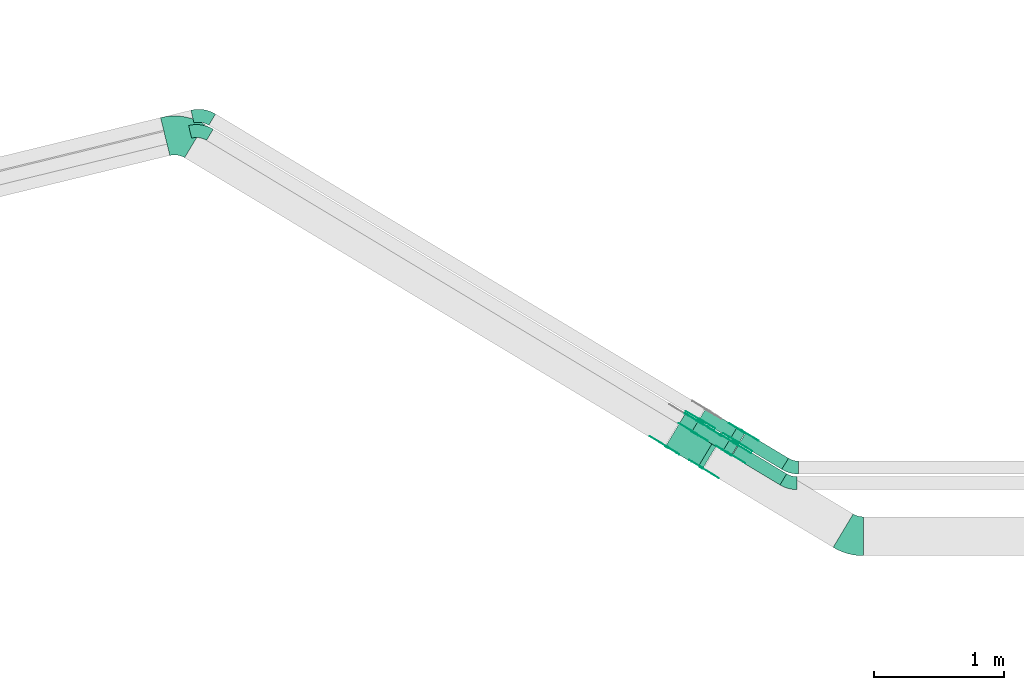
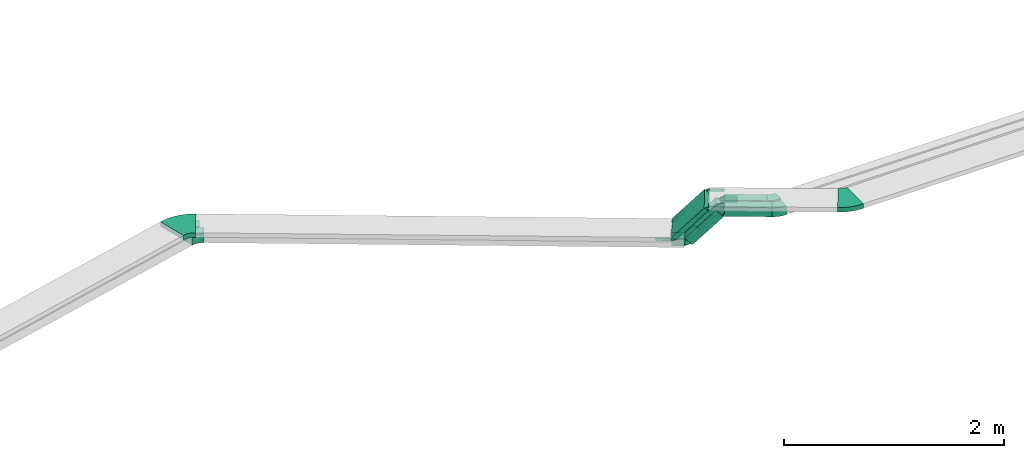
# One storey, part 4 of 28: 27 flow fittings, 5 flow segments.
"""IFC2X3 building model written with IfcOpenShell, lengths in millimetres."""

from ifc_helpers import new_model, entity, si_unit, converted_unit, derived_unit, direction, frame, frame_2d, origin, origin_2d_with_axis, place, context, subcontext, project, spatial, polyline, circle_curve, parameter, trimmed, segment, composite_curve, rectangle, outline, extrude, source, transform, mapped, material, type_object, type_shapes, element, save


model = new_model("IFC2X3")

# Units and contexts
model_context = context("Model", 3, precision=0.01, world=origin(), true_north=direction((6.12303176911189e-17, 1.0)))
body_context = subcontext(model_context, "Body", "Model", "MODEL_VIEW")
ifc_project = project(units=[si_unit("LENGTHUNIT", "METRE", prefix="MILLI"), si_unit("AREAUNIT", "SQUARE_METRE"), si_unit("VOLUMEUNIT", "CUBIC_METRE"), converted_unit("PLANEANGLEUNIT", "DEGREE", entity("IfcRatioMeasure", 0.0174532925199433), si_unit("PLANEANGLEUNIT", "RADIAN"), dimensions=[0, 0, 0, 0, 0, 0, 0]), si_unit("MASSUNIT", "GRAM", prefix="KILO"), derived_unit("MASSDENSITYUNIT", [(si_unit("MASSUNIT", "GRAM", prefix="KILO"), 1), (si_unit("LENGTHUNIT", "METRE"), -3)]), derived_unit("MOMENTOFINERTIAUNIT", [(si_unit("LENGTHUNIT", "METRE"), 4)]), si_unit("TIMEUNIT", "SECOND"), si_unit("FREQUENCYUNIT", "HERTZ"), si_unit("THERMODYNAMICTEMPERATUREUNIT", "DEGREE_CELSIUS"), derived_unit("THERMALTRANSMITTANCEUNIT", [(si_unit("MASSUNIT", "GRAM", prefix="KILO"), 1), (si_unit("THERMODYNAMICTEMPERATUREUNIT", "KELVIN"), -1), (si_unit("TIMEUNIT", "SECOND"), -3)]), derived_unit("VOLUMETRICFLOWRATEUNIT", [(si_unit("LENGTHUNIT", "METRE"), 3), (si_unit("TIMEUNIT", "SECOND"), -1)]), derived_unit("MASSFLOWRATEUNIT", [(si_unit("MASSUNIT", "GRAM", prefix="KILO"), 1), (si_unit("TIMEUNIT", "SECOND"), -1)]), derived_unit("ROTATIONALFREQUENCYUNIT", [(si_unit("TIMEUNIT", "SECOND"), -1)]), si_unit("ELECTRICCURRENTUNIT", "AMPERE"), si_unit("ELECTRICVOLTAGEUNIT", "VOLT"), si_unit("POWERUNIT", "WATT"), si_unit("FORCEUNIT", "NEWTON", prefix="KILO"), si_unit("ILLUMINANCEUNIT", "LUX"), si_unit("LUMINOUSFLUXUNIT", "LUMEN"), si_unit("LUMINOUSINTENSITYUNIT", "CANDELA"), derived_unit("USERDEFINED", [(si_unit("MASSUNIT", "GRAM", prefix="KILO"), -1), (si_unit("LENGTHUNIT", "METRE"), -2), (si_unit("TIMEUNIT", "SECOND"), 3), (si_unit("LUMINOUSFLUXUNIT", "LUMEN"), 1)]), derived_unit("LINEARVELOCITYUNIT", [(si_unit("LENGTHUNIT", "METRE"), 1), (si_unit("TIMEUNIT", "SECOND"), -1)]), si_unit("PRESSUREUNIT", "PASCAL"), derived_unit("USERDEFINED", [(si_unit("LENGTHUNIT", "METRE"), -2), (si_unit("MASSUNIT", "GRAM", prefix="KILO"), 1), (si_unit("TIMEUNIT", "SECOND"), -2)]), derived_unit("LINEARFORCEUNIT", [(si_unit("MASSUNIT", "GRAM", prefix="KILO"), 1), (si_unit("LENGTHUNIT", "METRE"), 1), (si_unit("TIMEUNIT", "SECOND"), -2), (si_unit("LENGTHUNIT", "METRE"), -1)]), derived_unit("PLANARFORCEUNIT", [(si_unit("MASSUNIT", "GRAM", prefix="KILO"), 1), (si_unit("LENGTHUNIT", "METRE"), 1), (si_unit("TIMEUNIT", "SECOND"), -2), (si_unit("LENGTHUNIT", "METRE"), -2)])], contexts=[model_context])

# Site, building, storey
site_placement = place(None, frame((0.0, -0.00077364408347762, 0.0)))
site = spatial("IfcSite", under=ifc_project, at=site_placement, CompositionType="ELEMENT")
building_placement = place(site_placement, origin())
building = spatial("IfcBuilding", under=site, at=building_placement, CompositionType="ELEMENT")
storey_placement = place(building_placement, origin())
storey = spatial("IfcBuildingStorey", under=building, at=storey_placement, CompositionType="ELEMENT", Elevation=0.0)

# Flow segments
cable_carrier_segment_type = type_object("IfcCableCarrierSegmentType", PredefinedType="CABLETRAYSEGMENT")
flow_segment_1_placement = place(storey_placement, frame((2555.69421085965, 12171.2232739347, 2950.0)))
element("IfcFlowSegment", 1, at=flow_segment_1_placement, inside=storey, type_object=cable_carrier_segment_type, context=body_context, shape_type="SweptSolid", body=[
    extrude(rectangle(XDim=432.962240895032, YDim=99.9999999999993, at=frame_2d((5.54223333892878e-13, -9.30810983845731e-13), x_axis=(1.0, 0.0))), frame((211.312441412464, 154.35438456478, 0.0), z_axis=(0.0, 0.0, 1.0), x_axis=(-0.857167300702077, 0.515038074910114, 0.0)), (0.0, 0.0, 1.0), 99.9999999999994),
])
flow_segment_2_placement = place(storey_placement, frame((2612.34839909974, 12291.2232739347, 2950.0)))
element("IfcFlowSegment", 2, at=flow_segment_2_placement, inside=storey, type_object=cable_carrier_segment_type, context=body_context, shape_type="SweptSolid", body=[
    extrude(rectangle(XDim=383.040500784393, YDim=99.9999999999987, at=origin_2d_with_axis()), frame((189.916799803971, 141.498586103402, 0.0), z_axis=(0.0, 0.0, 1.0), x_axis=(-0.85716730070208, 0.515038074910108, 0.0)), (0.0, 0.0, 1.0), 100.0),
])
flow_segment_3_placement = place(storey_placement, frame((2246.6130509426, 12396.6059703295, 2635.15356176418)))
element("IfcFlowSegment", 3, at=flow_segment_3_placement, inside=storey, type_object=cable_carrier_segment_type, context=body_context, shape_type="SweptSolid", body=[
    extrude(rectangle(XDim=100.000000000001, YDim=99.9999999999976, at=frame_2d((7.105427357601e-14, -2.66453525910038e-13), x_axis=(0.0, 1.0))), frame((57.6018759497638, 207.045010762525, 33.456530317943), z_axis=(0.57355687566977, -0.344627739362477, 0.743144825477403), x_axis=(-0.515038074910093, -0.857167300702089, 0.0)), (0.0, 0.0, 1.0), 420.88675734891),
])
flow_segment_4_placement = place(storey_placement, frame((2043.89963280788, 12294.8769607346, 2818.6100920821)))
element("IfcFlowSegment", 4, at=flow_segment_4_placement, inside=storey, type_object=cable_carrier_segment_type, context=body_context, shape_type="SweptSolid", body=[
    extrude(rectangle(XDim=50.0000000000007, YDim=300.0, at=frame_2d((0.0, 0.0), x_axis=(0.0, 1.0))), frame((93.1806973386387, 290.864951591254, 16.728265158971), z_axis=(0.573556875669757, -0.344627739362442, 0.74314482547743), x_axis=(0.515038074910054, 0.857167300702113, 0.0)), (0.0, 0.0, 1.0), 443.148191614342),
])
flow_segment_5_placement = place(storey_placement, frame((2303.26723918157, 12490.8943734069, 2635.15356176534)))
element("IfcFlowSegment", 5, at=flow_segment_5_placement, inside=storey, type_object=cable_carrier_segment_type, context=body_context, shape_type="SweptSolid", body=[
    extrude(rectangle(XDim=100.0, YDim=99.999999999998, at=frame_2d((-1.45661260830821e-13, 1.74082970261225e-13), x_axis=(0.0, 1.0))), frame((57.6018759496271, 207.045010763197, 33.4565303181206), z_axis=(0.573556875672807, -0.344627739364302, 0.743144825474213), x_axis=(-0.515038074910098, -0.857167300702086, 0.0)), (0.0, 0.0, 1.0), 420.886757348871),
])

# Flow fittings
ifc_material_1 = material(Name="G")
cable_carrier_fitting_type_1 = type_object("IfcCableCarrierFittingType", PredefinedType="NOTDEFINED", material=ifc_material_1)
shared_shape_1 = source(origin(), body_context, "Body", "SweptSolid", [
    extrude(outline(composite_curve([segment(trimmed(circle_curve(frame_2d((-44.5901162790698, 0.0), x_axis=(1.0, 0.0)), 12.5), [parameter(90.0000000000007)], [parameter(270.0)], True, "PARAMETER"), True, "CONTINUOUS"), segment(polyline([(-44.5901162790697, -12.5), (-33.0901162790698, -12.5)]), True, "CONTINUOUS"), segment(polyline([(-33.0901162790698, -12.5), (-31.2296511627907, -14.5)]), True, "CONTINUOUS"), segment(polyline([(-31.2296511627907, -14.5), (108.90988372093, -14.5)]), True, "CONTINUOUS"), segment(polyline([(108.90988372093, -14.5), (108.90988372093, 14.5)]), True, "CONTINUOUS"), segment(polyline([(108.90988372093, 14.5), (-31.2296511627907, 14.5)]), True, "CONTINUOUS"), segment(polyline([(-31.2296511627907, 14.5), (-33.0901162790698, 12.5)]), True, "CONTINUOUS"), segment(polyline([(-33.0901162790698, 12.5), (-44.5901162790699, 12.5)]), True, "CONTINUOUS")], self_intersect=False)), frame((44.5901162790698, 0.0, 0.0), z_axis=(0.0, 0.0, -1.0), x_axis=(1.0, 0.0, 0.0)), (0.0, 0.0, -1.0), 2.0),
])
type_shapes(cable_carrier_fitting_type_1, [shared_shape_1])
for number, where, z_axis, x_axis in (
    (6, (2054.18377965179, 12465.8526910006, 2825.0), (-0.515038074910058, -0.85716730070211, 0.0), (0.57355687566975, -0.344627739362441, 0.743144825477436)),
    (7, (2474.14757288229, 12552.9099741725, 3175.0), (0.515038074910075, 0.8571673007021, 0.0), (0.8571673007021, -0.515038074910075, 0.0)),
):
    element("IfcFlowFitting", number, at=place(storey_placement, frame(where, z_axis=z_axis, x_axis=x_axis)), inside=storey, type_object=cable_carrier_fitting_type_1, material=ifc_material_1, context=body_context, shape_type="MappedRepresentation", body=[
        mapped(shared_shape_1, transform((0.0, 0.0, 0.0), scale=1.0)),
    ])
cable_carrier_fitting_type_2 = type_object("IfcCableCarrierFittingType", PredefinedType="NOTDEFINED", material=ifc_material_1)
shared_shape_2 = source(origin(), body_context, "Body", "SweptSolid", [
    extrude(outline(composite_curve([segment(trimmed(circle_curve(frame_2d((-44.5901162790697, 0.0), x_axis=(1.0, 0.0)), 12.5), [parameter(90.0000000000007)], [parameter(270.0)], True, "PARAMETER"), True, "CONTINUOUS"), segment(polyline([(-44.5901162790697, -12.5), (-33.0901162790697, -12.5)]), True, "CONTINUOUS"), segment(polyline([(-33.0901162790697, -12.5), (-31.2296511627907, -14.5)]), True, "CONTINUOUS"), segment(polyline([(-31.2296511627907, -14.5), (108.90988372093, -14.5)]), True, "CONTINUOUS"), segment(polyline([(108.90988372093, -14.5), (108.90988372093, 14.5)]), True, "CONTINUOUS"), segment(polyline([(108.90988372093, 14.5), (-31.2296511627907, 14.5)]), True, "CONTINUOUS"), segment(polyline([(-31.2296511627907, 14.5), (-33.0901162790698, 12.5)]), True, "CONTINUOUS"), segment(polyline([(-33.0901162790698, 12.5), (-44.5901162790699, 12.5)]), True, "CONTINUOUS")], self_intersect=False)), frame((44.5901162790697, 0.0, 0.0)), (0.0, 0.0, 1.0), 2.0),
])
type_shapes(cable_carrier_fitting_type_2, [shared_shape_2])
for number, where, z_axis, x_axis in (
    (8, (2204.01865641509, 12715.2198021382, 2825.0), (0.515038074910066, 0.857167300702105, 0.0), (0.573556875669743, -0.344627739362453, 0.743144825477436)),
    (9, (2324.31269611898, 12303.5428630348, 3175.0), (-0.515038074910064, -0.857167300702107, 0.0), (0.857167300702107, -0.515038074910064, 0.0)),
):
    element("IfcFlowFitting", number, at=place(storey_placement, frame(where, z_axis=z_axis, x_axis=x_axis)), inside=storey, type_object=cable_carrier_fitting_type_2, material=ifc_material_1, context=body_context, shape_type="MappedRepresentation", body=[
        mapped(shared_shape_2, transform((0.0, 0.0, 0.0), scale=1.0)),
    ])
cable_carrier_fitting_type_3 = type_object("IfcCableCarrierFittingType", PredefinedType="NOTDEFINED", material=ifc_material_1)
shared_shape_3 = source(origin(), body_context, "Body", "SweptSolid", [
    extrude(outline(composite_curve([segment(trimmed(circle_curve(frame_2d((-44.5901162790698, 0.0), x_axis=(1.0, 0.0)), 12.5), [parameter(90.0000000000007)], [parameter(270.0)], True, "PARAMETER"), True, "CONTINUOUS"), segment(polyline([(-44.5901162790697, -12.5), (-33.0901162790698, -12.5)]), True, "CONTINUOUS"), segment(polyline([(-33.0901162790698, -12.5), (-31.2296511627907, -14.5)]), True, "CONTINUOUS"), segment(polyline([(-31.2296511627907, -14.5), (108.90988372093, -14.5)]), True, "CONTINUOUS"), segment(polyline([(108.90988372093, -14.5), (108.90988372093, 14.5)]), True, "CONTINUOUS"), segment(polyline([(108.90988372093, 14.5), (-31.2296511627907, 14.5)]), True, "CONTINUOUS"), segment(polyline([(-31.2296511627907, 14.5), (-33.0901162790698, 12.5)]), True, "CONTINUOUS"), segment(polyline([(-33.0901162790698, 12.5), (-44.5901162790699, 12.5)]), True, "CONTINUOUS")], self_intersect=False)), frame((44.5901162790698, 0.0, 0.0), z_axis=(0.0, 0.0, -1.0), x_axis=(1.0, 0.0, 0.0)), (0.0, 0.0, -1.0), 2.0),
])
type_shapes(cable_carrier_fitting_type_3, [shared_shape_3])
flow_fitting_1_placement = place(storey_placement, frame((2325.3427722688, 12305.2571976362, 3175.0), z_axis=(-0.515038074910083, -0.857167300702095, 0.0), x_axis=(-0.57355687566976, 0.344627739362467, -0.743144825477416)))
element("IfcFlowFitting", 10, at=flow_fitting_1_placement, inside=storey, type_object=cable_carrier_fitting_type_3, material=ifc_material_1, context=body_context, shape_type="MappedRepresentation", body=[
    mapped(shared_shape_3, transform((0.0, 0.0, 0.0), scale=1.0)),
])
cable_carrier_fitting_type_4 = type_object("IfcCableCarrierFittingType", PredefinedType="NOTDEFINED", material=ifc_material_1)
shared_shape_4 = source(origin(), body_context, "Body", "SweptSolid", [
    extrude(outline(composite_curve([segment(trimmed(circle_curve(frame_2d((-44.5901162790697, 0.0), x_axis=(1.0, 0.0)), 12.5), [parameter(90.0000000000007)], [parameter(270.0)], True, "PARAMETER"), True, "CONTINUOUS"), segment(polyline([(-44.5901162790697, -12.5), (-33.0901162790697, -12.5)]), True, "CONTINUOUS"), segment(polyline([(-33.0901162790697, -12.5), (-31.2296511627907, -14.5)]), True, "CONTINUOUS"), segment(polyline([(-31.2296511627907, -14.5), (108.90988372093, -14.5)]), True, "CONTINUOUS"), segment(polyline([(108.90988372093, -14.5), (108.90988372093, 14.5)]), True, "CONTINUOUS"), segment(polyline([(108.90988372093, 14.5), (-31.2296511627907, 14.5)]), True, "CONTINUOUS"), segment(polyline([(-31.2296511627907, 14.5), (-33.0901162790698, 12.5)]), True, "CONTINUOUS"), segment(polyline([(-33.0901162790698, 12.5), (-44.5901162790699, 12.5)]), True, "CONTINUOUS")], self_intersect=False)), frame((44.5901162790697, 0.0, 0.0)), (0.0, 0.0, 1.0), 2.0),
])
type_shapes(cable_carrier_fitting_type_4, [shared_shape_4])
for number, where, z_axis, x_axis in (
    (11, (2055.21385580161, 12467.567025602, 2825.0), (-0.51503807491007, -0.857167300702103, 0.0), (-0.857167300702103, 0.51503807491007, 0.0)),
    (12, (2473.11749673247, 12551.1956395711, 3175.0), (0.515038074910059, 0.85716730070211, 0.0), (-0.573556875669774, 0.344627739362443, -0.743144825477416)),
):
    element("IfcFlowFitting", number, at=place(storey_placement, frame(where, z_axis=z_axis, x_axis=x_axis)), inside=storey, type_object=cable_carrier_fitting_type_4, material=ifc_material_1, context=body_context, shape_type="MappedRepresentation", body=[
        mapped(shared_shape_4, transform((0.0, 0.0, 0.0), scale=1.0)),
    ])
cable_carrier_fitting_type_5 = type_object("IfcCableCarrierFittingType", PredefinedType="NOTDEFINED", material=ifc_material_1)
shared_shape_5 = source(origin(), body_context, "Body", "SweptSolid", [
    extrude(outline(composite_curve([segment(trimmed(circle_curve(frame_2d((-41.4651162790697, 0.0), x_axis=(1.0, 0.0)), 25.0), [parameter(90.0000000000007)], [parameter(270.0)], True, "PARAMETER"), True, "CONTINUOUS"), segment(polyline([(-41.4651162790697, -25.0), (-29.9651162790697, -25.0)]), True, "CONTINUOUS"), segment(polyline([(-29.9651162790697, -25.0), (-28.1046511627907, -38.5)]), True, "CONTINUOUS"), segment(polyline([(-28.1046511627907, -38.5), (99.5348837209303, -38.5)]), True, "CONTINUOUS"), segment(polyline([(99.5348837209303, -38.5), (99.5348837209303, 38.5)]), True, "CONTINUOUS"), segment(polyline([(99.5348837209303, 38.5), (-28.1046511627907, 38.5)]), True, "CONTINUOUS"), segment(polyline([(-28.1046511627907, 38.5), (-29.9651162790697, 25.0)]), True, "CONTINUOUS"), segment(polyline([(-29.9651162790697, 25.0), (-41.46511627907, 25.0)]), True, "CONTINUOUS")], self_intersect=False)), frame((41.4651162790697, 0.0, 0.0), z_axis=(0.0, 0.0, -1.0), x_axis=(1.0, 0.0, 0.0)), (0.0, 0.0, -1.0), 2.0),
])
type_shapes(cable_carrier_fitting_type_5, [shared_shape_5])
for number, where, z_axis, x_axis in (
    (13, (2536.56700101323, 12411.0046157542, 3000.0), (-0.515038074910089, -0.857167300702091, 0.0), (-0.573556875669768, 0.344627739362478, -0.743144825477405)),
    (14, (2266.43808454603, 12573.3144437199, 2650.0), (-0.515038074910057, -0.857167300702111, 0.0), (0.57355687566977, -0.344627739362475, 0.743144825477405)),
    (15, (2640.04845103461, 12583.2266698287, 3000.0), (0.5150380749101, 0.857167300702085, 0.0), (0.857167300702085, -0.5150380749101, 0.0)),
):
    element("IfcFlowFitting", number, at=place(storey_placement, frame(where, z_axis=z_axis, x_axis=x_axis)), inside=storey, type_object=cable_carrier_fitting_type_5, material=ifc_material_1, context=body_context, shape_type="MappedRepresentation", body=[
        mapped(shared_shape_5, transform((0.0, 0.0, 0.0), scale=1.0)),
    ])
cable_carrier_fitting_type_6 = type_object("IfcCableCarrierFittingType", PredefinedType="NOTDEFINED", material=ifc_material_1)
shared_shape_6 = source(origin(), body_context, "Body", "SweptSolid", [
    extrude(outline(composite_curve([segment(trimmed(circle_curve(frame_2d((-41.4651162790697, 0.0), x_axis=(1.0, 0.0)), 25.0), [parameter(90.0000000000007)], [parameter(270.0)], True, "PARAMETER"), True, "CONTINUOUS"), segment(polyline([(-41.4651162790697, -25.0), (-29.9651162790697, -25.0)]), True, "CONTINUOUS"), segment(polyline([(-29.9651162790697, -25.0), (-28.1046511627907, -38.5)]), True, "CONTINUOUS"), segment(polyline([(-28.1046511627907, -38.5), (99.5348837209303, -38.5)]), True, "CONTINUOUS"), segment(polyline([(99.5348837209303, -38.5), (99.5348837209303, 38.5)]), True, "CONTINUOUS"), segment(polyline([(99.5348837209303, 38.5), (-28.1046511627907, 38.5)]), True, "CONTINUOUS"), segment(polyline([(-28.1046511627907, 38.5), (-29.9651162790697, 25.0)]), True, "CONTINUOUS"), segment(polyline([(-29.9651162790697, 25.0), (-41.46511627907, 25.0)]), True, "CONTINUOUS")], self_intersect=False)), frame((41.4651162790697, 0.0, 0.0)), (0.0, 0.0, 1.0), 2.0),
])
type_shapes(cable_carrier_fitting_type_6, [shared_shape_6])
for number, where, z_axis, x_axis in (
    (16, (2583.39426279452, 12488.9382667514, 3000.0), (0.515038074910081, 0.857167300702096, 0.0), (-0.573556875669775, 0.344627739362466, -0.743144825477405)),
    (17, (2313.26534632732, 12651.2480947172, 2650.0), (0.515038074910065, 0.857167300702106, 0.0), (0.573556875669763, -0.344627739362486, 0.743144825477405)),
    (18, (2593.22118925332, 12505.2930188314, 3000.0), (-0.515038074910088, -0.857167300702092, 0.0), (0.857167300702092, -0.515038074910088, 0.0)),
    (19, (2323.09227278487, 12667.6028467979, 2650.0), (-0.515038074910067, -0.857167300702105, 0.0), (-0.857167300702105, 0.515038074910067, 0.0)),
):
    element("IfcFlowFitting", number, at=place(storey_placement, frame(where, z_axis=z_axis, x_axis=x_axis)), inside=storey, type_object=cable_carrier_fitting_type_6, material=ifc_material_1, context=body_context, shape_type="MappedRepresentation", body=[
        mapped(shared_shape_6, transform((0.0, 0.0, 0.0), scale=1.0)),
    ])
cable_carrier_fitting_type_7 = type_object("IfcCableCarrierFittingType", PredefinedType="NOTDEFINED", material=ifc_material_1)
shared_shape_7 = source(origin(), body_context, "Body", "SweptSolid", [
    extrude(outline(composite_curve([segment(trimmed(circle_curve(frame_2d((-41.4651162790697, 0.0), x_axis=(1.0, 0.0)), 25.0), [parameter(90.0000000000007)], [parameter(270.0)], True, "PARAMETER"), True, "CONTINUOUS"), segment(polyline([(-41.4651162790697, -25.0), (-29.9651162790697, -25.0)]), True, "CONTINUOUS"), segment(polyline([(-29.9651162790697, -25.0), (-28.1046511627907, -38.5)]), True, "CONTINUOUS"), segment(polyline([(-28.1046511627907, -38.5), (99.5348837209303, -38.5)]), True, "CONTINUOUS"), segment(polyline([(99.5348837209303, -38.5), (99.5348837209303, 38.5)]), True, "CONTINUOUS"), segment(polyline([(99.5348837209303, 38.5), (-28.1046511627907, 38.5)]), True, "CONTINUOUS"), segment(polyline([(-28.1046511627907, 38.5), (-29.9651162790697, 25.0)]), True, "CONTINUOUS"), segment(polyline([(-29.9651162790697, 25.0), (-41.46511627907, 25.0)]), True, "CONTINUOUS")], self_intersect=False)), frame((41.4651162790697, 0.0, 0.0), z_axis=(0.0, 0.0, -1.0), x_axis=(1.0, 0.0, 0.0)), (0.0, 0.0, -1.0), 2.0),
])
type_shapes(cable_carrier_fitting_type_7, [shared_shape_7])
for number, where, z_axis, x_axis in (
    (20, (2582.3641866447, 12487.22393215, 3000.0), (0.5150380749101, 0.857167300702084, 0.0), (0.857167300702084, -0.5150380749101, 0.0)),
    (21, (2312.2352701775, 12649.5337601158, 2650.0), (0.515038074910046, 0.857167300702118, 0.0), (-0.857167300702118, 0.515038074910046, 0.0)),
    (22, (2594.25126540314, 12507.0073534328, 3000.0), (-0.515038074910108, -0.85716730070208, 0.0), (-0.573556875669665, 0.344627739362432, -0.743144825477505)),
    (23, (2324.12234893469, 12669.3171813993, 2650.0), (-0.515038074910047, -0.857167300702117, 0.0), (0.573556875669679, -0.344627739362409, 0.743144825477505)),
):
    element("IfcFlowFitting", number, at=place(storey_placement, frame(where, z_axis=z_axis, x_axis=x_axis)), inside=storey, type_object=cable_carrier_fitting_type_7, material=ifc_material_1, context=body_context, shape_type="MappedRepresentation", body=[
        mapped(shared_shape_7, transform((0.0, 0.0, 0.0), scale=1.0)),
    ])
cable_carrier_fitting_type_8 = type_object("IfcCableCarrierFittingType", PredefinedType="NOTDEFINED", material=ifc_material_1)
shared_shape_8 = source(origin(), body_context, "Body", "SweptSolid", [
    extrude(outline(composite_curve([segment(trimmed(circle_curve(frame_2d((-41.4651162790697, 0.0), x_axis=(1.0, 0.0)), 25.0), [parameter(90.0000000000007)], [parameter(270.0)], True, "PARAMETER"), True, "CONTINUOUS"), segment(polyline([(-41.4651162790697, -25.0), (-29.9651162790697, -25.0)]), True, "CONTINUOUS"), segment(polyline([(-29.9651162790697, -25.0), (-28.1046511627907, -38.5)]), True, "CONTINUOUS"), segment(polyline([(-28.1046511627907, -38.5), (99.5348837209303, -38.5)]), True, "CONTINUOUS"), segment(polyline([(99.5348837209303, -38.5), (99.5348837209303, 38.5)]), True, "CONTINUOUS"), segment(polyline([(99.5348837209303, 38.5), (-28.1046511627907, 38.5)]), True, "CONTINUOUS"), segment(polyline([(-28.1046511627907, 38.5), (-29.9651162790697, 25.0)]), True, "CONTINUOUS"), segment(polyline([(-29.9651162790697, 25.0), (-41.46511627907, 25.0)]), True, "CONTINUOUS")], self_intersect=False)), frame((41.4651162790697, 0.0, 0.0)), (0.0, 0.0, 1.0), 2.0),
])
type_shapes(cable_carrier_fitting_type_8, [shared_shape_8])
for number, where, z_axis, x_axis in (
    (24, (2537.59707716305, 12412.7189503556, 3000.0), (-0.515038074910077, -0.857167300702098, 0.0), (0.857167300702098, -0.515038074910077, 0.0)),
    (25, (2267.46816069585, 12575.0287783213, 2650.0), (-0.515038074910069, -0.857167300702104, 0.0), (-0.857167300702104, 0.515038074910069, 0.0)),
    (26, (2639.01837488479, 12581.5123352273, 3000.0), (0.515038074910083, 0.857167300702095, 0.0), (-0.573556875669679, 0.344627739362409, -0.743144825477505)),
):
    element("IfcFlowFitting", number, at=place(storey_placement, frame(where, z_axis=z_axis, x_axis=x_axis)), inside=storey, type_object=cable_carrier_fitting_type_8, material=ifc_material_1, context=body_context, shape_type="MappedRepresentation", body=[
        mapped(shared_shape_8, transform((0.0, 0.0, 0.0), scale=1.0)),
    ])
ifc_material_2 = material()
cable_carrier_fitting_type_9 = type_object("IfcCableCarrierFittingType", Name="470_DKC_S5_Variable Angle Elbow 0-45:-", PredefinedType="NOTDEFINED", material=ifc_material_2)
shared_shape_9 = source(origin(), body_context, "Body", "SweptSolid", [
    extrude(outline(composite_curve([segment(polyline([(-52.4680993161816, -64.4120294485169), (-51.4680993161802, -64.4120294485169)]), True, "CONTINUOUS"), segment(trimmed(circle_curve(frame_2d((-51.4680993161828, 185.587970551483), x_axis=(0.0, -1.0)), 250.0), [parameter(0.0)], [parameter(31.0000000000001)], True, "PARAMETER"), True, "CONTINUOUS"), segment(polyline([(77.2914194113333, -28.7038546240434), (78.1485867120354, -28.1888165491333)]), True, "CONTINUOUS"), segment(polyline([(78.1485867120354, -28.1888165491333), (26.6447792210289, 57.5279135210772)]), True, "CONTINUOUS"), segment(polyline([(26.6447792210289, 57.5279135210772), (25.7876119203268, 57.0128754461671)]), True, "CONTINUOUS"), segment(trimmed(circle_curve(frame_2d((-51.4680993161828, 185.587970551483), x_axis=(0.0, -1.0)), 150.0), [parameter(0.0)], [parameter(31.0000000000001)], True, "PARAMETER"), False, "CONTINUOUS"), segment(polyline([(-51.4680993161811, 35.5879705514829), (-52.4680993161824, 35.5879705514829)]), True, "CONTINUOUS"), segment(polyline([(-52.4680993161824, 35.5879705514829), (-52.4680993161816, -64.4120294485169)]), True, "CONTINUOUS")], self_intersect=False)), frame((-3.9968094957771, 14.4120294485084, -50.0)), (0.0, 0.0, 1.0), 100.0),
])
type_shapes(cable_carrier_fitting_type_9, [shared_shape_9])
for number, where, z_axis, x_axis, name in (
    (27, (3000.96706340982, 12185.0000610354, 3000.0), (0.0, 0.0, 1.0), (0.85716730070211, -0.515038074910058, 0.0), "470_DKC_S5_Variable Angle Elbow 0-45:-"),
    (28, (3014.82996843292, 12305.0000610354, 3000.0), (0.0, 0.0, 1.0), (0.857167300702094, -0.515038074910084, 0.0), "470_DKC_S5_Variable Angle Elbow 0-45:-"),
):
    element("IfcFlowFitting", number, at=place(storey_placement, frame(where, z_axis=z_axis, x_axis=x_axis)), inside=storey, type_object=cable_carrier_fitting_type_9, material=ifc_material_2, Name=name, ObjectType="470_DKC_S5_Variable Angle Elbow 0-45:-", context=body_context, shape_type="MappedRepresentation", body=[
        mapped(shared_shape_9, transform((0.0, 0.0, 0.0), scale=1.0)),
    ])
cable_carrier_fitting_type_10 = type_object("IfcCableCarrierFittingType", Name="470_DKC_S5_Variable Angle Elbow 0-45:-", PredefinedType="NOTDEFINED", material=ifc_material_2)
shared_shape_10 = source(origin(), body_context, "Body", "SweptSolid", [
    extrude(outline(composite_curve([segment(polyline([(-71.265899594772, -79.0946376898054), (-70.2658995947706, -79.0946376898054)]), True, "CONTINUOUS"), segment(trimmed(circle_curve(frame_2d((-70.2658995947732, 170.905362310194), x_axis=(0.0, -1.0)), 250.0), [parameter(0.0)], [parameter(44.6989733065183)], True, "PARAMETER"), True, "CONTINUOUS"), segment(polyline([(105.579591843397, -6.79765719388745), (106.290403921414, -6.09427522813478)]), True, "CONTINUOUS"), segment(polyline([(106.290403921414, -6.0942752281348), (35.9522073461455, 64.986932573498)]), True, "CONTINUOUS"), segment(polyline([(35.9522073461455, 64.986932573498), (35.2413952681291, 64.2835506077453)]), True, "CONTINUOUS"), segment(trimmed(circle_curve(frame_2d((-70.2658995947732, 170.905362310194), x_axis=(0.0, -1.0)), 150.0), [parameter(0.0)], [parameter(44.6989733065183)], True, "PARAMETER"), False, "CONTINUOUS"), segment(polyline([(-70.2658995947714, 20.9053623101945), (-71.2658995947728, 20.9053623101945)]), True, "CONTINUOUS"), segment(polyline([(-71.2658995947728, 20.9053623101945), (-71.265899594772, -79.0946376898054)]), True, "CONTINUOUS")], self_intersect=False)), frame((-11.9619470274191, 29.0946376897967, -50.0)), (0.0, 0.0, 1.0), 100.0),
])
type_shapes(cable_carrier_fitting_type_10, [shared_shape_10])
for number, where, z_axis, x_axis, name in (
    (29, (-1539.65051665123, 14913.2783509583, 2650.0), (0.0, 0.0, 1.0), (-0.857167300702109, 0.51503807491006, 0.0), "470_DKC_S5_Variable Angle Elbow 0-45:-"),
    (30, (-1521.76199014356, 15030.8595135411, 2650.0), (0.0, 0.0, 1.0), (-0.857167300702113, 0.515038074910054, 0.0), "470_DKC_S5_Variable Angle Elbow 0-45:-"),
):
    element("IfcFlowFitting", number, at=place(storey_placement, frame(where, z_axis=z_axis, x_axis=x_axis)), inside=storey, type_object=cable_carrier_fitting_type_10, material=ifc_material_2, Name=name, ObjectType="470_DKC_S5_Variable Angle Elbow 0-45:-", context=body_context, shape_type="MappedRepresentation", body=[
        mapped(shared_shape_10, transform((0.0, 0.0, 0.0), scale=1.0)),
    ])
cable_carrier_fitting_type_11 = type_object("IfcCableCarrierFittingType", Name="470_DKC_S5_Variable Angle Elbow 0-45:-", PredefinedType="NOTDEFINED", material=ifc_material_2)
shared_shape_11 = source(origin(), body_context, "Body", "SweptSolid", [
    extrude(outline(composite_curve([segment(polyline([(-78.2200030616823, -171.553664413412), (-77.220003061681, -171.553664413412)]), True, "CONTINUOUS"), segment(trimmed(circle_curve(frame_2d((-77.2200030616891, 278.446335586587), x_axis=(0.0, -1.0)), 450.0), [parameter(0.0)], [parameter(31.0000000000002)], True, "PARAMETER"), True, "CONTINUOUS"), segment(polyline([(154.547130647844, -107.278949729358), (155.404297948546, -106.763911654448)]), True, "CONTINUOUS"), segment(polyline([(155.404297948546, -106.763911654448), (0.892875475524254, 150.386278556183)]), True, "CONTINUOUS"), segment(polyline([(0.892875475524288, 150.386278556183), (0.0357081748219245, 149.871240481272)]), True, "CONTINUOUS"), segment(trimmed(circle_curve(frame_2d((-77.2200030616891, 278.446335586587), x_axis=(0.0, -1.0)), 150.0), [parameter(0.0)], [parameter(31.0000000000002)], True, "PARAMETER"), False, "CONTINUOUS"), segment(polyline([(-77.220003061686, 128.446335586588), (-78.2200030616874, 128.446335586587)]), True, "CONTINUOUS"), segment(polyline([(-78.2200030616874, 128.446335586587), (-78.2200030616823, -171.553664413412)]), True, "CONTINUOUS")], self_intersect=False)), frame((-5.97736015625825, 21.553664413403, -25.0)), (0.0, 0.0, 1.0), 49.9999999999988),
])
type_shapes(cable_carrier_fitting_type_11, [shared_shape_11])
flow_fitting_2_placement = place(storey_placement, frame((3485.93479317479, 11775.2683846926, 3175.0), z_axis=(0.0, 0.0, 1.0), x_axis=(0.857167300702103, -0.515038074910069, 0.0)))
element("IfcFlowFitting", 31, at=flow_fitting_2_placement, inside=storey, type_object=cable_carrier_fitting_type_11, material=ifc_material_2, Name="470_DKC_S5_Variable Angle Elbow 0-45:-", ObjectType="470_DKC_S5_Variable Angle Elbow 0-45:-", context=body_context, shape_type="MappedRepresentation", body=[
    mapped(shared_shape_11, transform((0.0, 0.0, 0.0), scale=1.0)),
])
cable_carrier_fitting_type_12 = type_object("IfcCableCarrierFittingType", Name="470_DKC_S5_Variable Angle Elbow 0-45:-", PredefinedType="NOTDEFINED", material=ifc_material_2)
shared_shape_12 = source(origin(), body_context, "Body", "SweptSolid", [
    extrude(outline(composite_curve([segment(polyline([(-106.434997882403, -193.55403378899), (-105.434997882401, -193.55403378899)]), True, "CONTINUOUS"), segment(trimmed(circle_curve(frame_2d((-105.43499788241, 256.44596621101), x_axis=(0.0, -1.0)), 450.0), [parameter(0.0)], [parameter(44.6989733065181)], True, "PARAMETER"), True, "CONTINUOUS"), segment(polyline([(211.086886706299, -63.4194688963355), (211.797698784315, -62.7160869305838)]), True, "CONTINUOUS"), segment(polyline([(211.797698784315, -62.7160869305838), (0.783109058510487, 150.527536474315)]), True, "CONTINUOUS"), segment(polyline([(0.783109058510487, 150.527536474315), (0.0722969804931298, 149.824154508562)]), True, "CONTINUOUS"), segment(trimmed(circle_curve(frame_2d((-105.43499788241, 256.44596621101), x_axis=(0.0, -1.0)), 150.0), [parameter(0.0)], [parameter(44.6989733065181)], True, "PARAMETER"), False, "CONTINUOUS"), segment(polyline([(-105.434997882406, 106.44596621101), (-106.434997882408, 106.44596621101)]), True, "CONTINUOUS"), segment(polyline([(-106.434997882408, 106.44596621101), (-106.434997882403, -193.55403378899)]), True, "CONTINUOUS")], self_intersect=False)), frame((-17.9067720508851, 43.5540337889797, -25.0)), (0.0, 0.0, 1.0), 49.9999999999983),
])
type_shapes(cable_carrier_fitting_type_12, [shared_shape_12])
flow_fitting_3_placement = place(storey_placement, frame((-1691.94050309811, 14886.4497404587, 2825.0), z_axis=(0.0, 0.0, 1.0), x_axis=(-0.857167300702109, 0.515038074910059, 0.0)))
element("IfcFlowFitting", 32, at=flow_fitting_3_placement, inside=storey, type_object=cable_carrier_fitting_type_12, material=ifc_material_2, Name="470_DKC_S5_Variable Angle Elbow 0-45:-", ObjectType="470_DKC_S5_Variable Angle Elbow 0-45:-", context=body_context, shape_type="MappedRepresentation", body=[
    mapped(shared_shape_12, transform((0.0, 0.0, 0.0), scale=1.0)),
])

save(model, "model.ifc")
